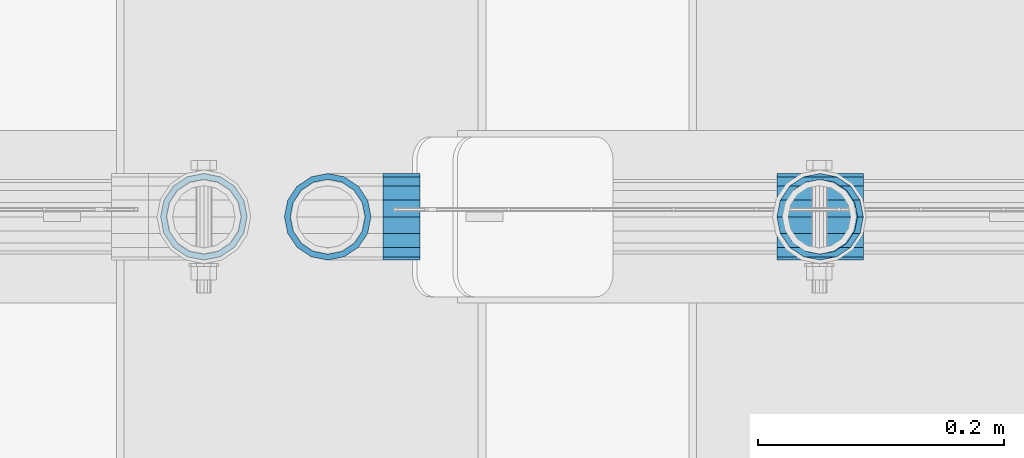
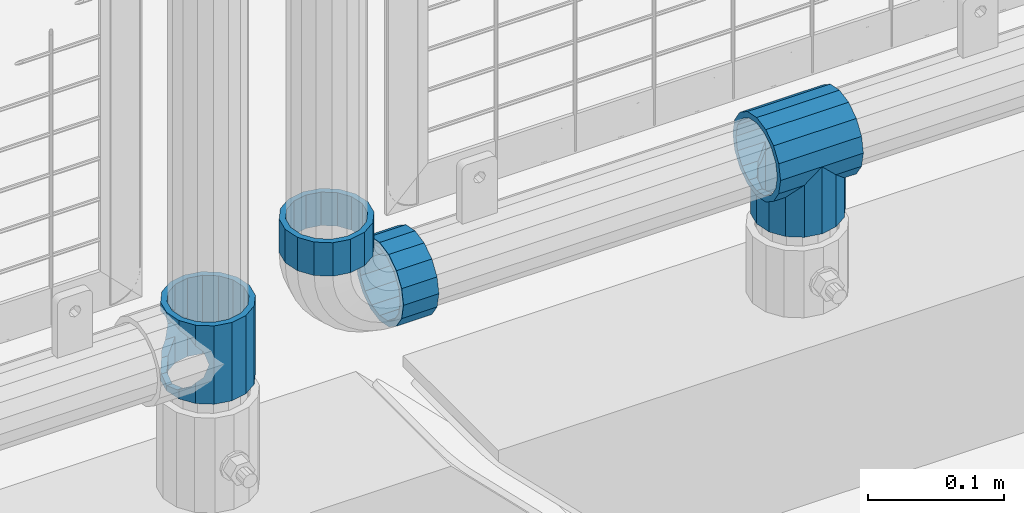
# One storey, part 167 of 247: 5 beams.
"""IFC2X3 building model written with IfcOpenShell, lengths in millimetres."""

from ifc_helpers import new_model, si_unit, frame, origin_with_axes, place, context, subcontext, project, spatial, faceted_brep, material, type_object, element, save


model = new_model("IFC2X3")

# Units and contexts
model_context = context("Model", 3, precision=1e-05, world=origin_with_axes())
body_context = subcontext(model_context, "Body", "Model", "MODEL_VIEW")
ifc_project = project(units=[si_unit("LENGTHUNIT", "METRE", prefix="MILLI"), si_unit("AREAUNIT", "SQUARE_METRE"), si_unit("VOLUMEUNIT", "CUBIC_METRE"), si_unit("MASSUNIT", "GRAM", prefix="KILO"), si_unit("TIMEUNIT", "SECOND"), si_unit("PLANEANGLEUNIT", "RADIAN"), si_unit("SOLIDANGLEUNIT", "STERADIAN"), si_unit("THERMODYNAMICTEMPERATUREUNIT", "DEGREE_CELSIUS"), si_unit("LUMINOUSINTENSITYUNIT", "LUMEN")], contexts=[model_context])

# Site, building, storey
site_placement = place(None, origin_with_axes())
site = spatial("IfcSite", under=ifc_project, at=site_placement, CompositionType="ELEMENT")
building_placement = place(site_placement, origin_with_axes())
building = spatial("IfcBuilding", under=site, at=building_placement, Name="Standard", CompositionType="ELEMENT")
storey_placement = place(building_placement, origin_with_axes())
storey = spatial("IfcBuildingStorey", under=building, at=storey_placement, Name="Undefined", CompositionType="ELEMENT", Elevation=0.0)

# Beams
ifc_material = material(Name="Misc_Undefined")
beam_type = type_object("IfcBeamType", PredefinedType="NOTDEFINED")
beam_1_placement = place(storey_placement, frame((15021.0, 7664.5, 333.820000000001), z_axis=(1.0, 0.0, 0.0), x_axis=(0.0, 0.0, -1.0)))
element("IfcBeam", 1, at=beam_1_placement, inside=storey, type_object=beam_type, material=ifc_material, context=body_context, shape_type="Brep", body=[
    faceted_brep([(46.7644421722801, 28.0397438117179, -11.6144421722802), (46.7644421722801, 28.0397438117179, -20.088203122983), (51.5310424080055, 24.8548033587067, -24.8548033587067), (56.6106908090114, 21.4606908090118, -27.1226768591096), (56.6106908090114, 21.4606908090118, -21.4606908090118), (61.9623795176755, 13.4513226476329, -32.4743655677721), (63.1897438117172, 11.6144421722802, -32.839743811719), (63.1897438117172, 11.6144421722802, -28.0397438117179), (65.4999999999997, 0.0, -35.1499999999996), (65.4999999999997, 0.0, -30.3500000000004), (63.1897438117172, -11.6144421722802, -32.839743811719), (63.1897438117172, -11.6144421722802, -28.0397438117179), (61.9623795176754, -13.4513226476329, -32.4743655677721), (56.6106908090114, -21.4606908090118, -27.1226768591077), (56.6106908090114, -21.4606908090118, -21.4606908090118), (51.5310424080038, -24.8548033587067, -24.8548033587067), (46.7644421722801, -28.0397438117179, -20.0882031229885), (46.7644421722801, -28.0397438117179, -11.6144421722802), (35.1499999999996, -30.3500000000004, -16.6306603983739), (35.1499999999996, -30.35, 0.0), (23.5355578277191, -28.0397438117179, -20.0882031229885), (23.5355578277191, -28.0397438117179, -11.6144421722802), (18.768957591997, -24.8548033587067, -24.8548033587067), (13.6893091909879, -21.4606908090118, -27.1226768591077), (13.6893091909879, -21.4606908090118, -21.4606908090118), (8.33762048232325, -13.4513226476329, -32.4743655677721), (7.11025618828211, -11.6144421722802, -32.839743811719), (7.11025618828211, -11.6144421722802, -28.0397438117179), (4.79999999999961, 0.0, -35.1499999999996), (4.79999999999961, 0.0, -30.3500000000004), (7.11025618828211, 11.6144421722802, -32.839743811719), (7.11025618828211, 11.6144421722802, -28.0397438117179), (8.33762048232387, 13.4513226476329, -32.4743655677721), (13.6893091909879, 21.4606908090118, -27.1226768591096), (13.6893091909879, 21.4606908090118, -21.4606908090118), (18.768957591997, 24.8548033587067, -24.8548033587067), (23.5355578277192, 28.0397438117179, -20.088203122983), (23.5355578277192, 28.0397438117179, -11.6144421722802), (35.1499999999996, 30.3500000000004, -16.6306603983649), (35.1499999999996, 30.35, 0.0), (0.0, 32.4743655677721, -13.4513226476338), (0.0, 35.1499999999996, 0.0), (70.2999999999993, 35.1499999999996, 0.0), (70.2999999999993, 32.4743655677721, -13.4513226476338), (0.0, 32.4743655677721, 13.4513226476338), (70.2999999999993, 32.4743655677721, 13.4513226476338), (0.0, 24.8548033587067, 24.8548033587067), (70.2999999999993, 24.8548033587067, 24.8548033587067), (0.0, 13.4513226476329, 32.4743655677721), (70.2999999999993, 13.4513226476329, 32.4743655677721), (0.0, 0.0, 35.1499999999996), (70.2999999999993, 0.0, 35.1499999999996), (0.0, -13.4513226476329, 32.4743655677721), (70.2999999999993, -13.4513226476329, 32.4743655677721), (0.0, -24.8548033587067, 24.8548033587067), (70.2999999999993, -24.8548033587067, 24.8548033587067), (0.0, -32.4743655677721, 13.4513226476338), (70.2999999999993, -32.4743655677721, 13.4513226476338), (0.0, -35.1499999999996, 0.0), (70.2999999999993, -35.1499999999996, 0.0), (70.2999999999993, -30.3500000000004, 0.0), (70.2999999999993, -28.0397438117179, -11.6144421722802), (70.2999999999993, -21.4606908090118, -21.4606908090118), (70.2999999999993, -11.6144421722802, -28.0397438117179), (70.2999999999993, 0.0, -30.3500000000004), (70.2999999999993, 11.6144421722802, -28.0397438117179), (70.2999999999993, 21.4606908090118, -21.4606908090118), (70.2999999999993, 28.0397438117179, -11.6144421722802), (0.0, -28.0397438117179, -11.6144421722802), (0.0, -30.3500000000004, 0.0), (0.0, -21.4606908090118, -21.4606908090118), (0.0, -11.6144421722802, -28.0397438117179), (0.0, 0.0, -30.3500000000004), (0.0, 11.6144421722802, -28.0397438117179), (0.0, 21.4606908090118, -21.4606908090118), (0.0, 28.0397438117179, -11.6144421722802), (0.0, 30.3500000000004, 0.0), (70.2999999999993, 30.3500000000004, 0.0), (0.0, 28.0397438117179, 11.6144421722802), (70.2999999999993, 28.0397438117179, 11.6144421722802), (0.0, 21.4606908090118, 21.4606908090118), (70.2999999999993, 21.4606908090118, 21.4606908090118), (0.0, 11.6144421722802, 28.0397438117179), (70.2999999999993, 11.6144421722802, 28.0397438117179), (0.0, 0.0, 30.3500000000004), (70.2999999999993, 0.0, 30.3500000000004), (0.0, -11.6144421722802, 28.0397438117179), (70.2999999999993, -11.6144421722802, 28.0397438117179), (0.0, -21.4606908090118, 21.4606908090118), (70.2999999999993, -21.4606908090118, 21.4606908090118), (0.0, -28.0397438117179, 11.6144421722802), (70.2999999999993, -28.0397438117179, 11.6144421722802), (70.2999999999993, -24.8548033587067, -24.8548033587067), (70.2999999999993, -13.4513226476329, -32.4743655677721), (70.2999999999993, 0.0, -35.1499999999996), (70.2999999999993, 13.4513226476329, -32.4743655677721), (70.2999999999993, 24.8548033587067, -24.8548033587067), (70.2999999999993, -32.4743655677721, -13.4513226476338), (0.0, -32.4743655677721, -13.4513226476338), (0.0, 24.8548033587067, -24.8548033587067), (0.0, 13.4513226476329, -32.4743655677721), (0.0, 0.0, -35.1499999999996), (0.0, -13.4513226476329, -32.4743655677721), (0.0, -24.8548033587067, -24.8548033587067)], [[[0, 1, 2, 3, 4]], [[4, 3, 5, 6, 7]], [[7, 6, 8, 9]], [[9, 8, 10, 11]], [[11, 10, 12, 13, 14]], [[14, 13, 15, 16, 17]], [[17, 16, 18, 19]], [[19, 18, 20, 21]], [[21, 20, 22, 23, 24]], [[24, 23, 25, 26, 27]], [[27, 26, 28, 29]], [[29, 28, 30, 31]], [[31, 30, 32, 33, 34]], [[34, 33, 35, 36, 37]], [[37, 36, 38, 39]], [[39, 38, 1, 0]], [[40, 41, 42, 43]], [[41, 44, 45, 42]], [[44, 46, 47, 45]], [[46, 48, 49, 47]], [[48, 50, 51, 49]], [[50, 52, 53, 51]], [[52, 54, 55, 53]], [[54, 56, 57, 55]], [[56, 58, 59, 57]], [[60, 61, 17, 19]], [[61, 62, 14, 17]], [[62, 63, 11, 14]], [[63, 64, 9, 11]], [[64, 65, 7, 9]], [[65, 66, 4, 7]], [[66, 67, 0, 4]], [[68, 69, 19, 21]], [[70, 68, 21, 24]], [[71, 70, 24, 27]], [[72, 71, 27, 29]], [[73, 72, 29, 31]], [[74, 73, 31, 34]], [[75, 74, 34, 37]], [[76, 75, 37, 39]], [[67, 77, 39, 0]], [[78, 76, 39, 77, 79]], [[80, 78, 79, 81]], [[82, 80, 81, 83]], [[84, 82, 83, 85]], [[86, 84, 85, 87]], [[88, 86, 87, 89]], [[90, 88, 89, 91]], [[19, 69, 90, 91, 60]], [[92, 93, 94, 95, 96, 43, 42, 45, 47, 49, 51, 53, 55, 57, 59, 97], [89, 87, 85, 83, 81, 79, 77, 67, 66, 65, 64, 63, 62, 61, 60, 91]], [[58, 98, 97, 59]], [[56, 54, 52, 50, 48, 46, 44, 41, 40, 99, 100, 101, 102, 103, 98, 58], [68, 70, 71, 72, 73, 74, 75, 76, 78, 80, 82, 84, 86, 88, 90, 69]], [[32, 100, 99, 35, 33]], [[28, 101, 100, 32, 30]], [[102, 101, 28, 26, 25]], [[103, 102, 25, 23, 22]], [[15, 92, 97, 98, 103, 22, 20, 18, 16]], [[12, 93, 92, 15, 13]], [[8, 94, 93, 12, 10]], [[95, 94, 8, 6, 5]], [[96, 95, 5, 3, 2]], [[35, 99, 40, 43, 96, 2, 1, 38, 36]]]),
])
beam_2_placement = place(storey_placement, frame((15521.61, 7664.5, 298.169999999999), z_axis=(0.0, 1.0, 0.0), x_axis=(0.0, 0.0, -1.0)))
element("IfcBeam", 2, at=beam_2_placement, inside=storey, type_object=beam_type, material=ifc_material, context=body_context, shape_type="Brep", body=[
    faceted_brep([(0.0, 0.0, 35.1499999999996), (13.4513226476338, 13.4513226476329, 32.4743655677721), (13.4513226476338, -13.4513226476329, 32.4743655677721), (24.8548033587067, -16.3810424080045, -24.8548033587067), (24.8548033587067, -24.8548033587072, -24.8548033587067), (32.4743655677721, -32.4743655677717, -13.4513226476329), (32.4743655677721, -26.8123795176766, -13.4513226476329), (27.1226768591059, -21.4606908090117, -21.4606908090118), (0.0, 0.0, -35.1499999999996), (13.4513226476338, -13.4513226476329, -32.4743655677721), (13.4513226476338, 13.4513226476329, -32.4743655677721), (20.0882031229885, -11.6144421722805, -28.0397438117179), (16.6306603983739, 0.0, -30.3500000000004), (20.0882031229885, 11.6144421722805, -28.0397438117179), (24.8548033587067, 16.3810424080029, -24.8548033587067), (24.8548033587067, 24.8548033587072, -24.8548033587067), (27.1226768591059, 21.4606908090117, -21.4606908090118), (32.4743655677721, 26.8123795176755, -13.4513226476329), (32.4743655677721, 32.4743655677717, -13.4513226476329), (32.8397438117172, 28.0397438117175, -11.6144421722802), (35.1499999999996, 30.35, 0.0), (35.1499999999996, 35.15, 0.0), (32.8397438117172, 28.0397438117175, 11.6144421722802), (32.4743655677721, 26.8123795176755, 13.4513226476329), (32.4743655677721, 32.4743655677717, 13.4513226476329), (27.1226768591096, 21.4606908090117, 21.4606908090118), (24.8548033587067, 16.3810424080046, 24.8548033587067), (24.8548033587067, 24.8548033587072, 24.8548033587067), (20.0882031229812, 11.6144421722805, 28.0397438117179), (16.6306603983649, 0.0, 30.3500000000004), (20.0882031229812, -11.6144421722805, 28.0397438117179), (24.8548033587067, -16.3810424080045, 24.8548033587067), (24.8548033587067, -24.8548033587072, 24.8548033587067), (27.1226768591096, -21.4606908090117, 21.4606908090118), (32.4743655677721, -26.8123795176755, 13.4513226476329), (32.4743655677721, -32.4743655677717, 13.4513226476329), (32.8397438117172, -28.0397438117175, 11.6144421722802), (35.1499999999996, -30.35, 0.0), (35.1499999999996, -35.15, 0.0), (32.8397438117172, -28.0397438117175, -11.6144421722802), (60.1499999999996, -24.8548033587072, -24.8548033587067), (60.1499999999996, -32.4743655677717, -13.4513226476329), (60.1499999999996, -13.4513226476329, -32.4743655677721), (60.1499999999996, 0.0, -35.1499999999996), (60.1499999999996, 13.4513226476329, -32.4743655677721), (60.1499999999996, 24.8548033587072, -24.8548033587067), (60.1499999999996, 32.4743655677717, -13.4513226476329), (60.1499999999996, 35.15, 0.0), (60.1499999999996, 32.4743655677717, 13.4513226476329), (60.1499999999996, 24.8548033587072, 24.8548033587067), (60.1499999999996, 13.4513226476329, 32.4743655677721), (60.1499999999996, 0.0, 35.1499999999996), (60.1499999999996, -13.4513226476329, 32.4743655677721), (60.1499999999996, -24.8548033587072, 24.8548033587067), (60.1499999999996, -32.4743655677717, 13.4513226476329), (60.1499999999996, -35.15, 0.0), (60.1499999999996, -21.4606908090117, 21.4606908090118), (60.1499999999996, -11.6144421722805, 28.0397438117179), (60.1499999999996, 0.0, 30.3500000000004), (60.1499999999996, 11.6144421722805, 28.0397438117179), (60.1499999999996, 21.4606908090117, 21.4606908090118), (60.1499999999996, 28.0397438117175, 11.6144421722802), (60.1499999999996, 30.35, 0.0), (60.1499999999996, 28.0397438117175, -11.6144421722802), (60.1499999999996, 21.4606908090117, -21.4606908090118), (60.1499999999996, 11.6144421722805, -28.0397438117179), (60.1499999999996, 0.0, -30.3500000000004), (60.1499999999996, -11.6144421722805, -28.0397438117179), (60.1499999999996, -21.4606908090117, -21.4606908090118), (60.1499999999996, -28.0397438117175, -11.6144421722802), (60.1499999999996, -30.35, 0.0), (60.1499999999996, -28.0397438117175, 11.6144421722802)], [[[0, 1, 2]], [[3, 4, 5, 6, 7]], [[8, 9, 10]], [[10, 9, 4, 3, 11, 12, 13, 14, 15]], [[15, 14, 16, 17, 18]], [[18, 17, 19, 20, 21]], [[21, 20, 22, 23, 24]], [[24, 23, 25, 26, 27]], [[27, 26, 28, 29, 30, 31, 32, 2, 1]], [[33, 34, 35, 32, 31]], [[36, 37, 38, 35, 34]], [[6, 5, 38, 37, 39]], [[40, 41, 5, 4]], [[42, 40, 4, 9]], [[43, 42, 9, 8]], [[44, 43, 8, 10]], [[45, 44, 10, 15]], [[46, 45, 15, 18]], [[47, 46, 18, 21]], [[48, 47, 21, 24]], [[49, 48, 24, 27]], [[50, 49, 27, 1]], [[51, 50, 1, 0]], [[52, 51, 0, 2]], [[53, 52, 2, 32]], [[54, 53, 32, 35]], [[55, 54, 35, 38]], [[41, 55, 38, 5]], [[40, 42, 43, 44, 45, 46, 47, 48, 49, 50, 51, 52, 53, 54, 55, 41], [56, 57, 58, 59, 60, 61, 62, 63, 64, 65, 66, 67, 68, 69, 70, 71]], [[71, 70, 37, 36]], [[56, 71, 36, 34, 33]], [[57, 56, 33, 31, 30]], [[58, 57, 30, 29]], [[59, 58, 29, 28]], [[25, 60, 59, 28, 26]], [[22, 61, 60, 25, 23]], [[62, 61, 22, 20]], [[63, 62, 20, 19]], [[64, 63, 19, 17, 16]], [[65, 64, 16, 14, 13]], [[66, 65, 13, 12]], [[67, 66, 12, 11]], [[7, 68, 67, 11, 3]], [[39, 69, 68, 7, 6]], [[70, 69, 39, 37]]]),
])
beam_3_placement = place(storey_placement, frame((15486.46, 7664.5, 298.169999999999), z_axis=(0.0, 0.0, 1.0), x_axis=(1.0, 0.0, 0.0)))
element("IfcBeam", 3, at=beam_3_placement, inside=storey, type_object=beam_type, material=ifc_material, context=body_context, shape_type="Brep", body=[
    faceted_brep([(63.1897438117172, -11.6144421722802, -28.0397438117179), (63.1897438117172, -11.6144421722802, -32.839743811719), (61.9623795176754, -13.4513226476329, -32.4743655677721), (56.6106908090114, -21.4606908090118, -27.1226768591077), (56.6106908090114, -21.4606908090118, -21.4606908090118), (51.5310424080038, -24.8548033587067, -24.8548033587067), (46.7644421722801, -28.0397438117179, -20.0882031229885), (46.7644421722801, -28.0397438117179, -11.6144421722802), (35.1499999999996, -30.3500000000004, -16.6306603983739), (35.1499999999996, -30.35, 0.0), (23.5355578277191, -28.0397438117179, -20.0882031229885), (23.5355578277191, -28.0397438117179, -11.6144421722802), (18.768957591997, -24.8548033587067, -24.8548033587067), (13.6893091909879, -21.4606908090118, -27.1226768591077), (13.6893091909879, -21.4606908090118, -21.4606908090118), (8.33762048232325, -13.4513226476329, -32.4743655677721), (7.11025618828211, -11.6144421722802, -32.839743811719), (7.11025618828211, -11.6144421722802, -28.0397438117179), (4.79999999999961, 0.0, -35.1499999999996), (4.79999999999961, 0.0, -30.3500000000004), (7.11025618828211, 11.6144421722802, -32.839743811719), (7.11025618828211, 11.6144421722802, -28.0397438117179), (8.33762048232387, 13.4513226476329, -32.4743655677721), (13.6893091909879, 21.4606908090118, -27.1226768591096), (13.6893091909879, 21.4606908090118, -21.4606908090118), (18.768957591997, 24.8548033587067, -24.8548033587067), (23.5355578277192, 28.0397438117179, -20.088203122983), (23.5355578277192, 28.0397438117179, -11.6144421722802), (35.1499999999996, 30.3500000000004, -16.6306603983649), (35.1499999999996, 30.35, 0.0), (46.7644421722801, 28.0397438117179, -20.088203122983), (46.7644421722801, 28.0397438117179, -11.6144421722802), (51.5310424080055, 24.8548033587067, -24.8548033587067), (56.6106908090114, 21.4606908090118, -27.1226768591096), (56.6106908090114, 21.4606908090118, -21.4606908090118), (61.9623795176755, 13.4513226476329, -32.4743655677721), (63.1897438117172, 11.6144421722802, -32.839743811719), (63.1897438117172, 11.6144421722802, -28.0397438117179), (65.4999999999997, 0.0, -35.1499999999996), (65.4999999999997, 0.0, -30.3500000000004), (0.0, -21.4606908090118, -21.4606908090118), (0.0, -28.0397438117179, -11.6144421722802), (0.0, -11.6144421722802, -28.0397438117179), (0.0, 0.0, -30.3500000000004), (0.0, 11.6144421722802, -28.0397438117179), (0.0, 21.4606908090118, -21.4606908090118), (0.0, 28.0397438117179, -11.6144421722802), (0.0, 30.3500000000004, 0.0), (0.0, 32.4743655677721, -13.4513226476338), (0.0, 35.1499999999996, 0.0), (70.2999999999993, 35.1499999999996, 0.0), (70.2999999999993, 32.4743655677721, -13.4513226476338), (0.0, 32.4743655677721, 13.4513226476338), (70.2999999999993, 32.4743655677721, 13.4513226476338), (0.0, 24.8548033587067, 24.8548033587067), (70.2999999999993, 24.8548033587067, 24.8548033587067), (0.0, 13.4513226476329, 32.4743655677721), (70.2999999999993, 13.4513226476329, 32.4743655677721), (0.0, 0.0, 35.1499999999996), (70.2999999999993, 0.0, 35.1499999999996), (0.0, -13.4513226476329, 32.4743655677721), (70.2999999999993, -13.4513226476329, 32.4743655677721), (0.0, -24.8548033587067, 24.8548033587067), (70.2999999999993, -24.8548033587067, 24.8548033587067), (0.0, -32.4743655677721, 13.4513226476338), (70.2999999999993, -32.4743655677721, 13.4513226476338), (0.0, -35.1499999999996, 0.0), (70.2999999999993, -35.1499999999996, 0.0), (0.0, -32.4743655677721, -13.4513226476338), (70.2999999999993, -32.4743655677721, -13.4513226476338), (0.0, 24.8548033587067, -24.8548033587067), (0.0, 13.4513226476329, -32.4743655677721), (0.0, 0.0, -35.1499999999996), (0.0, -13.4513226476329, -32.4743655677721), (0.0, -24.8548033587067, -24.8548033587067), (0.0, 28.0397438117179, 11.6144421722802), (0.0, 21.4606908090118, 21.4606908090118), (0.0, 11.6144421722802, 28.0397438117179), (0.0, 0.0, 30.3500000000004), (0.0, -11.6144421722802, 28.0397438117179), (0.0, -21.4606908090118, 21.4606908090118), (0.0, -28.0397438117179, 11.6144421722802), (0.0, -30.3500000000004, 0.0), (70.2999999999993, -30.3500000000004, 0.0), (70.2999999999993, -28.0397438117179, -11.6144421722802), (70.2999999999993, -21.4606908090118, -21.4606908090118), (70.2999999999993, -11.6144421722802, -28.0397438117179), (70.2999999999993, 0.0, -30.3500000000004), (70.2999999999993, 21.4606908090118, -21.4606908090118), (70.2999999999993, 28.0397438117179, -11.6144421722802), (70.2999999999993, 11.6144421722802, -28.0397438117179), (70.2999999999993, 30.3500000000004, 0.0), (70.2999999999993, 28.0397438117179, 11.6144421722802), (70.2999999999993, 21.4606908090118, 21.4606908090118), (70.2999999999993, 11.6144421722802, 28.0397438117179), (70.2999999999993, 0.0, 30.3500000000004), (70.2999999999993, -11.6144421722802, 28.0397438117179), (70.2999999999993, -21.4606908090118, 21.4606908090118), (70.2999999999993, -28.0397438117179, 11.6144421722802), (70.2999999999993, -24.8548033587067, -24.8548033587067), (70.2999999999993, -13.4513226476329, -32.4743655677721), (70.2999999999993, 0.0, -35.1499999999996), (70.2999999999993, 13.4513226476329, -32.4743655677721), (70.2999999999993, 24.8548033587067, -24.8548033587067)], [[[0, 1, 2, 3, 4]], [[4, 3, 5, 6, 7]], [[7, 6, 8, 9]], [[9, 8, 10, 11]], [[11, 10, 12, 13, 14]], [[14, 13, 15, 16, 17]], [[17, 16, 18, 19]], [[19, 18, 20, 21]], [[21, 20, 22, 23, 24]], [[24, 23, 25, 26, 27]], [[27, 26, 28, 29]], [[29, 28, 30, 31]], [[31, 30, 32, 33, 34]], [[34, 33, 35, 36, 37]], [[37, 36, 38, 39]], [[39, 38, 1, 0]], [[40, 41, 11, 14]], [[42, 40, 14, 17]], [[43, 42, 17, 19]], [[44, 43, 19, 21]], [[45, 44, 21, 24]], [[46, 45, 24, 27]], [[47, 46, 27, 29]], [[48, 49, 50, 51]], [[49, 52, 53, 50]], [[52, 54, 55, 53]], [[54, 56, 57, 55]], [[56, 58, 59, 57]], [[58, 60, 61, 59]], [[60, 62, 63, 61]], [[62, 64, 65, 63]], [[64, 66, 67, 65]], [[66, 68, 69, 67]], [[64, 62, 60, 58, 56, 54, 52, 49, 48, 70, 71, 72, 73, 74, 68, 66], [41, 40, 42, 43, 44, 45, 46, 47, 75, 76, 77, 78, 79, 80, 81, 82]], [[41, 82, 9, 11]], [[83, 84, 7, 9]], [[84, 85, 4, 7]], [[85, 86, 0, 4]], [[86, 87, 39, 0]], [[88, 89, 31, 34]], [[90, 88, 34, 37]], [[87, 90, 37, 39]], [[89, 91, 29, 31]], [[75, 47, 29, 91, 92]], [[76, 75, 92, 93]], [[77, 76, 93, 94]], [[78, 77, 94, 95]], [[79, 78, 95, 96]], [[80, 79, 96, 97]], [[81, 80, 97, 98]], [[9, 82, 81, 98, 83]], [[99, 100, 101, 102, 103, 51, 50, 53, 55, 57, 59, 61, 63, 65, 67, 69], [97, 96, 95, 94, 93, 92, 91, 89, 88, 90, 87, 86, 85, 84, 83, 98]], [[102, 101, 38, 36, 35]], [[103, 102, 35, 33, 32]], [[25, 70, 48, 51, 103, 32, 30, 28, 26]], [[22, 71, 70, 25, 23]], [[18, 72, 71, 22, 20]], [[73, 72, 18, 16, 15]], [[74, 73, 15, 13, 12]], [[5, 99, 69, 68, 74, 12, 10, 8, 6]], [[2, 100, 99, 5, 3]], [[38, 101, 100, 2, 1]]]),
])
beam_4_placement = place(storey_placement, frame((15166.61, 7664.5, 298.170000000001), z_axis=(0.0, 0.0, -1.0), x_axis=(1.0, 0.0, 0.0)))
element("IfcBeam", 4, at=beam_4_placement, inside=storey, type_object=beam_type, material=ifc_material, context=body_context, shape_type="Brep", body=[
    faceted_brep([(0.0, -30.3500000000004, 0.0), (0.0, -28.0397438117179, 11.6144421722802), (30.0, -28.0397438117179, 11.6144421722805), (30.0, -30.3500000000004, 0.0), (0.0, -21.4606908090118, 21.4606908090118), (30.0, -21.4606908090118, 21.4606908090117), (0.0, -11.6144421722802, 28.0397438117179), (30.0, -11.6144421722802, 28.0397438117175), (0.0, 0.0, 30.3500000000004), (30.0, 0.0, 30.35), (0.0, 11.6144421722802, 28.0397438117179), (30.0, 11.6144421722802, 28.0397438117175), (0.0, 21.4606908090118, 21.4606908090118), (30.0, 21.4606908090118, 21.4606908090117), (0.0, 28.0397438117179, 11.6144421722802), (30.0, 28.0397438117179, 11.6144421722805), (0.0, 30.3500000000004, 0.0), (30.0, 30.3500000000004, 0.0), (0.0, 28.0397438117179, -11.6144421722802), (30.0, 28.0397438117179, -11.6144421722805), (0.0, 21.4606908090118, -21.4606908090118), (30.0, 21.4606908090118, -21.4606908090117), (0.0, 11.6144421722802, -28.0397438117179), (30.0, 11.6144421722802, -28.0397438117175), (0.0, 0.0, -30.3500000000004), (30.0, 0.0, -30.35), (0.0, -11.6144421722802, -28.0397438117179), (30.0, -11.6144421722802, -28.0397438117175), (0.0, -21.4606908090118, -21.4606908090118), (30.0, -21.4606908090118, -21.4606908090117), (0.0, -28.0397438117179, -11.6144421722802), (30.0, -28.0397438117179, -11.6144421722805), (0.0, -35.1499999999996, 0.0), (0.0, -32.4743655677721, -13.4513226476338), (30.0, -32.4743655677721, -13.4513226476329), (30.0, -35.1499999999996, 0.0), (0.0, -24.8548033587067, -24.8548033587067), (30.0, -24.8548033587067, -24.8548033587072), (0.0, -13.4513226476329, -32.4743655677721), (30.0, -13.4513226476329, -32.4743655677717), (0.0, 0.0, -35.1499999999996), (30.0, 0.0, -35.15), (0.0, 13.4513226476329, -32.4743655677721), (30.0, 13.4513226476329, -32.4743655677717), (0.0, 24.8548033587067, -24.8548033587067), (30.0, 24.8548033587067, -24.8548033587072), (0.0, 32.4743655677721, -13.4513226476338), (30.0, 32.4743655677721, -13.4513226476329), (0.0, 35.1499999999996, 0.0), (30.0, 35.1499999999996, 0.0), (0.0, 32.4743655677721, 13.4513226476338), (30.0, 32.4743655677721, 13.4513226476329), (0.0, 24.8548033587067, 24.8548033587067), (30.0, 24.8548033587067, 24.8548033587072), (0.0, 13.4513226476329, 32.4743655677721), (30.0, 13.4513226476329, 32.4743655677717), (0.0, 0.0, 35.1499999999996), (30.0, 0.0, 35.15), (0.0, -13.4513226476329, 32.4743655677721), (30.0, -13.4513226476329, 32.4743655677717), (0.0, -24.8548033587067, 24.8548033587067), (30.0, -24.8548033587067, 24.8548033587072), (0.0, -32.4743655677721, 13.4513226476338), (30.0, -32.4743655677721, 13.4513226476329)], [[[0, 1, 2, 3]], [[1, 4, 5, 2]], [[4, 6, 7, 5]], [[6, 8, 9, 7]], [[8, 10, 11, 9]], [[10, 12, 13, 11]], [[12, 14, 15, 13]], [[14, 16, 17, 15]], [[16, 18, 19, 17]], [[18, 20, 21, 19]], [[20, 22, 23, 21]], [[22, 24, 25, 23]], [[24, 26, 27, 25]], [[26, 28, 29, 27]], [[28, 30, 31, 29]], [[30, 0, 3, 31]], [[32, 33, 34, 35]], [[33, 36, 37, 34]], [[36, 38, 39, 37]], [[38, 40, 41, 39]], [[40, 42, 43, 41]], [[42, 44, 45, 43]], [[44, 46, 47, 45]], [[46, 48, 49, 47]], [[48, 50, 51, 49]], [[50, 52, 53, 51]], [[52, 54, 55, 53]], [[54, 56, 57, 55]], [[56, 58, 59, 57]], [[58, 60, 61, 59]], [[60, 62, 63, 61]], [[62, 32, 35, 63]], [[37, 39, 41, 43, 45, 47, 49, 51, 53, 55, 57, 59, 61, 63, 35, 34], [5, 7, 9, 11, 13, 15, 17, 19, 21, 23, 25, 27, 29, 31, 3, 2]], [[62, 60, 58, 56, 54, 52, 50, 48, 46, 44, 42, 40, 38, 36, 33, 32], [30, 28, 26, 24, 22, 20, 18, 16, 14, 12, 10, 8, 6, 4, 1, 0]]]),
])
beam_5_placement = place(storey_placement, frame((15121.61, 7664.5, 373.170000000002), z_axis=(-1.0, 0.0, 0.0), x_axis=(0.0, 0.0, -1.0)))
element("IfcBeam", 5, at=beam_5_placement, inside=storey, type_object=beam_type, material=ifc_material, context=body_context, shape_type="Brep", body=[
    faceted_brep([(0.0, -30.3500000000004, 0.0), (0.0, -28.0397438117179, 11.6144421722802), (30.0, -28.0397438117179, 11.6144421722805), (30.0, -30.3500000000004, 0.0), (0.0, -21.4606908090118, 21.4606908090118), (30.0, -21.4606908090118, 21.4606908090117), (0.0, -11.6144421722802, 28.0397438117179), (30.0, -11.6144421722802, 28.0397438117175), (0.0, 0.0, 30.3500000000004), (30.0, 0.0, 30.35), (0.0, 11.6144421722802, 28.0397438117179), (30.0, 11.6144421722802, 28.0397438117175), (0.0, 21.4606908090118, 21.4606908090118), (30.0, 21.4606908090118, 21.4606908090117), (0.0, 28.0397438117179, 11.6144421722802), (30.0, 28.0397438117179, 11.6144421722805), (0.0, 30.3500000000004, 0.0), (30.0, 30.3500000000004, 0.0), (0.0, 28.0397438117179, -11.6144421722802), (30.0, 28.0397438117179, -11.6144421722805), (0.0, 21.4606908090118, -21.4606908090118), (30.0, 21.4606908090118, -21.4606908090117), (0.0, 11.6144421722802, -28.0397438117179), (30.0, 11.6144421722802, -28.0397438117175), (0.0, 0.0, -30.3500000000004), (30.0, 0.0, -30.35), (0.0, -11.6144421722802, -28.0397438117179), (30.0, -11.6144421722802, -28.0397438117175), (0.0, -21.4606908090118, -21.4606908090118), (30.0, -21.4606908090118, -21.4606908090117), (0.0, -28.0397438117179, -11.6144421722802), (30.0, -28.0397438117179, -11.6144421722805), (0.0, -35.1499999999996, 0.0), (0.0, -32.4743655677721, -13.4513226476338), (30.0, -32.4743655677721, -13.4513226476329), (30.0, -35.1499999999996, 0.0), (0.0, -24.8548033587067, -24.8548033587067), (30.0, -24.8548033587067, -24.8548033587072), (0.0, -13.4513226476329, -32.4743655677721), (30.0, -13.4513226476329, -32.4743655677717), (0.0, 0.0, -35.1499999999996), (30.0, 0.0, -35.15), (0.0, 13.4513226476329, -32.4743655677721), (30.0, 13.4513226476329, -32.4743655677717), (0.0, 24.8548033587067, -24.8548033587067), (30.0, 24.8548033587067, -24.8548033587072), (0.0, 32.4743655677721, -13.4513226476338), (30.0, 32.4743655677721, -13.4513226476329), (0.0, 35.1499999999996, 0.0), (30.0, 35.1499999999996, 0.0), (0.0, 32.4743655677721, 13.4513226476338), (30.0, 32.4743655677721, 13.4513226476329), (0.0, 24.8548033587067, 24.8548033587067), (30.0, 24.8548033587067, 24.8548033587072), (0.0, 13.4513226476329, 32.4743655677721), (30.0, 13.4513226476329, 32.4743655677717), (0.0, 0.0, 35.1499999999996), (30.0, 0.0, 35.15), (0.0, -13.4513226476329, 32.4743655677721), (30.0, -13.4513226476329, 32.4743655677717), (0.0, -24.8548033587067, 24.8548033587067), (30.0, -24.8548033587067, 24.8548033587072), (0.0, -32.4743655677721, 13.4513226476338), (30.0, -32.4743655677721, 13.4513226476329)], [[[0, 1, 2, 3]], [[1, 4, 5, 2]], [[4, 6, 7, 5]], [[6, 8, 9, 7]], [[8, 10, 11, 9]], [[10, 12, 13, 11]], [[12, 14, 15, 13]], [[14, 16, 17, 15]], [[16, 18, 19, 17]], [[18, 20, 21, 19]], [[20, 22, 23, 21]], [[22, 24, 25, 23]], [[24, 26, 27, 25]], [[26, 28, 29, 27]], [[28, 30, 31, 29]], [[30, 0, 3, 31]], [[32, 33, 34, 35]], [[33, 36, 37, 34]], [[36, 38, 39, 37]], [[38, 40, 41, 39]], [[40, 42, 43, 41]], [[42, 44, 45, 43]], [[44, 46, 47, 45]], [[46, 48, 49, 47]], [[48, 50, 51, 49]], [[50, 52, 53, 51]], [[52, 54, 55, 53]], [[54, 56, 57, 55]], [[56, 58, 59, 57]], [[58, 60, 61, 59]], [[60, 62, 63, 61]], [[62, 32, 35, 63]], [[37, 39, 41, 43, 45, 47, 49, 51, 53, 55, 57, 59, 61, 63, 35, 34], [5, 7, 9, 11, 13, 15, 17, 19, 21, 23, 25, 27, 29, 31, 3, 2]], [[62, 60, 58, 56, 54, 52, 50, 48, 46, 44, 42, 40, 38, 36, 33, 32], [30, 28, 26, 24, 22, 20, 18, 16, 14, 12, 10, 8, 6, 4, 1, 0]]]),
])

save(model, "model.ifc")
